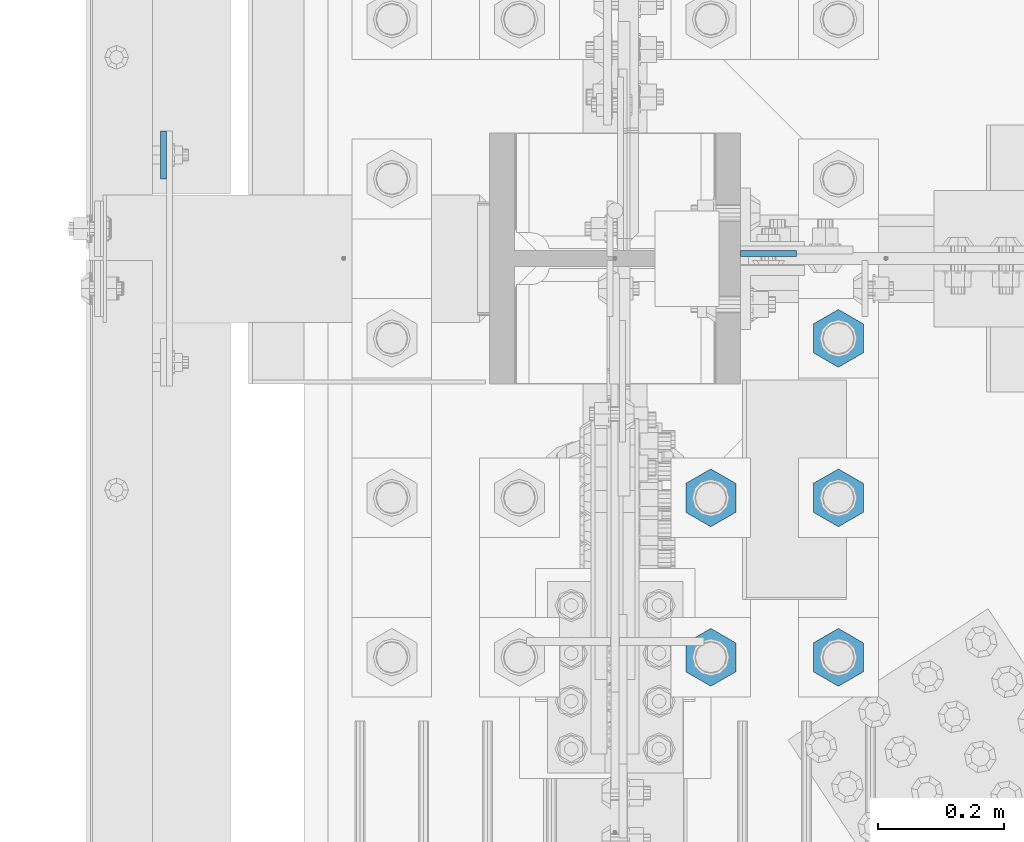
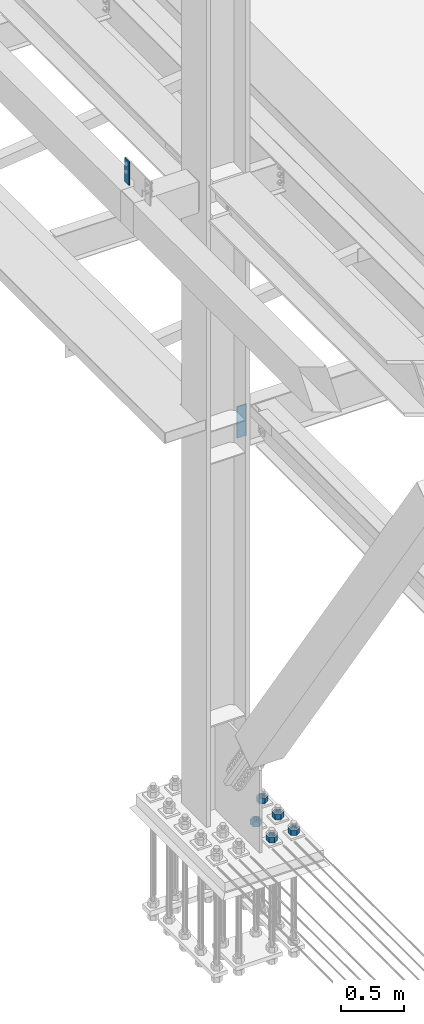
# One storey, part 1554 of 3843: 7 columns, 3 elements without a shape of their own.
"""IFC2X3 building model written with IfcOpenShell, lengths in millimetres."""

from ifc_helpers import new_model, si_unit, frame, origin_with_axes, place, context, subcontext, project, spatial, faceted_brep, material, type_object, element, aggregate, save


model = new_model("IFC2X3")

# Units and contexts
model_context = context("Model", 3, precision=1e-05, world=origin_with_axes())
body_context = subcontext(model_context, "Body", "Model", "MODEL_VIEW")
ifc_project = project(units=[si_unit("LENGTHUNIT", "METRE", prefix="MILLI"), si_unit("AREAUNIT", "SQUARE_METRE"), si_unit("VOLUMEUNIT", "CUBIC_METRE"), si_unit("MASSUNIT", "GRAM", prefix="KILO"), si_unit("TIMEUNIT", "SECOND"), si_unit("PLANEANGLEUNIT", "RADIAN"), si_unit("SOLIDANGLEUNIT", "STERADIAN"), si_unit("THERMODYNAMICTEMPERATUREUNIT", "DEGREE_CELSIUS"), si_unit("LUMINOUSINTENSITYUNIT", "LUMEN")], contexts=[model_context])

# Site, building, storey
site_placement = place(None, origin_with_axes())
site = spatial("IfcSite", under=ifc_project, at=site_placement, CompositionType="ELEMENT")
building_placement = place(site_placement, origin_with_axes())
building = spatial("IfcBuilding", under=site, at=building_placement, Name="Undefined", CompositionType="ELEMENT")
storey_placement = place(building_placement, origin_with_axes())
storey = spatial("IfcBuildingStorey", under=building, at=storey_placement, Name="Undefined", CompositionType="ELEMENT", Elevation=0.0)

# Assembly, column
assembly_1_placement = place(storey_placement, origin_with_axes())
assembly_1 = element("IfcElementAssembly", 1, at=assembly_1_placement, inside=storey, Name="GIRT", AssemblyPlace="NOTDEFINED", PredefinedType="RIGID_FRAME")
ifc_material = material(Name="STEEL/A572-50")
column_type_1 = type_object("IfcColumnType", PredefinedType="NOTDEFINED")
column_1_placement = place(assembly_1_placement, frame((35856.8625, 75793.6, 36404.55), z_axis=(0.0, 1.0, 0.0), x_axis=(0.0, 0.0, 1.0)))
column_1 = element("IfcColumn", 2, at=column_1_placement, type_object=column_type_1, material=ifc_material, Name="PLATE", context=body_context, shape_type="Brep", body=[
    faceted_brep([(0.0, 4.76250000000073, -38.0999999999985), (0.0, 4.76250000000073, 38.0999999999985), (228.599999999999, 4.76249999999709, 38.1000000000058), (228.599999999999, 4.76249999999709, -38.1000000000058), (0.0, -4.76250000000073, 38.0999999999985), (228.599999999999, -4.76249999999709, 38.1000000000058), (0.0, -4.76250000000073, -38.0999999999985), (228.599999999999, -4.76249999999709, -38.1000000000058)], [[[0, 1, 2, 3]], [[1, 4, 5, 2]], [[4, 6, 7, 5]], [[6, 0, 3, 7]], [[5, 7, 3, 2]], [[6, 4, 1, 0]]]),
])
aggregate(assembly_1, [column_1])

assembly_2_placement = place(storey_placement, origin_with_axes())
assembly_2 = element("IfcElementAssembly", 3, at=assembly_2_placement, inside=storey, Name="COLUMN", AssemblyPlace="NOTDEFINED", PredefinedType="RIGID_FRAME")
column_type_2 = type_object("IfcColumnType", PredefinedType="NOTDEFINED")
column_2_placement = place(assembly_2_placement, frame((36820.475, 75636.4375, 33693.0999993376), z_axis=(-1.0, 0.0, 0.0), x_axis=(0.0, 0.0, 1.0)))
column_2 = element("IfcColumn", 4, at=column_2_placement, type_object=column_type_2, material=ifc_material, Name="PLATE", context=body_context, shape_type="Brep", body=[
    faceted_brep([(0.0, 4.76249999999709, -44.4500000000007), (0.0, 4.76249999999709, 44.4500000000007), (304.799999999996, 4.76249999999709, 44.4500000000007), (304.799999999996, 4.76249999999709, -44.4500000000007), (0.0, -4.76249999999709, 44.4500000000007), (304.799999999996, -4.76249999999709, 44.4500000000007), (0.0, -4.76249999999709, -44.4500000000007), (304.799999999996, -4.76249999999709, -44.4500000000007)], [[[0, 1, 2, 3]], [[1, 4, 5, 2]], [[4, 6, 7, 5]], [[6, 0, 3, 7]], [[5, 7, 3, 2]], [[6, 4, 1, 0]]]),
])
aggregate(assembly_2, [column_2])

# Assembly, columns
assembly_3_placement = place(storey_placement, origin_with_axes())
assembly_3 = element("IfcElementAssembly", 5, at=assembly_3_placement, inside=storey, Name="TEMPLATE", AssemblyPlace="NOTDEFINED", PredefinedType="RIGID_FRAME")
column_type_3 = type_object("IfcColumnType", Name="2_HEAVY_HEX_NUT", PredefinedType="NOTDEFINED")
column_3_placement = place(assembly_3_placement, frame((36931.6, 74993.5, 30232.35), z_axis=(1.0, 0.0, 0.0), x_axis=(0.0, 0.0, -1.0)))
column_3 = element("IfcColumn", 6, at=column_3_placement, type_object=column_type_3, material=ifc_material, Name="NUT", ObjectType="2_HEAVY_HEX_NUT", context=body_context, shape_type="Brep", body=[
    faceted_brep([(0.0, -46.0369987487793, 0.0), (0.0, -23.0184993743896, -39.869213104248), (50.7999999999993, -23.0184993743896, -39.869213104248), (50.7999999999993, -46.0369987487793, 0.0), (0.0, 23.0184993743896, -39.869213104248), (50.7999999999993, 23.0184993743896, -39.869213104248), (0.0, 46.0369987487793, 0.0), (50.7999999999993, 46.0369987487793, 0.0), (0.0, 23.0184993743896, 39.869213104248), (50.7999999999993, 23.0184993743896, 39.869213104248), (0.0, -23.0184993743896, 39.869213104248), (50.7999999999993, -23.0184993743896, 39.869213104248), (0.0, 0.0, 26.1940002441406), (0.0, 11.3650617044477, 23.5999013092805), (50.7999999999993, 11.3650617044477, 23.5999013092805), (50.7999999999993, 0.0, 26.1940002441406), (0.0, 20.4791109456419, 16.3316083006721), (50.7999999999993, 20.4791109456419, 16.3316083006721), (0.0, 25.5370200498292, 5.82867859874386), (50.7999999999993, 25.5370200498292, 5.82867859874386), (0.0, 25.5370200498292, -5.82867859874386), (50.7999999999993, 25.5370200498292, -5.82867859874386), (0.0, 20.4791109456419, -16.3316083006721), (50.7999999999993, 20.4791109456419, -16.3316083006721), (0.0, 11.3650617044477, -23.5999013092805), (50.7999999999993, 11.3650617044477, -23.5999013092805), (0.0, 0.0, -26.1940002441406), (50.7999999999993, 0.0, -26.1940002441406), (0.0, -11.3650617044477, -23.5999013092805), (50.7999999999993, -11.3650617044477, -23.5999013092805), (0.0, -20.4791109456419, -16.3316083006721), (50.7999999999993, -20.4791109456419, -16.3316083006721), (0.0, -25.5370200498292, -5.82867859874386), (50.7999999999993, -25.5370200498292, -5.82867859874386), (0.0, -25.5370200498292, 5.82867859874386), (50.7999999999993, -25.5370200498292, 5.82867859874386), (0.0, -20.4791109456419, 16.3316083006721), (50.7999999999993, -20.4791109456419, 16.3316083006721), (0.0, -11.3650617044477, 23.5999013092805), (50.7999999999993, -11.3650617044477, 23.5999013092805)], [[[0, 1, 2, 3]], [[1, 4, 5, 2]], [[4, 6, 7, 5]], [[6, 8, 9, 7]], [[8, 10, 11, 9]], [[10, 0, 3, 11]], [[12, 13, 14, 15]], [[13, 16, 17, 14]], [[16, 18, 19, 17]], [[18, 20, 21, 19]], [[20, 22, 23, 21]], [[22, 24, 25, 23]], [[24, 26, 27, 25]], [[26, 28, 29, 27]], [[28, 30, 31, 29]], [[30, 32, 33, 31]], [[32, 34, 35, 33]], [[34, 36, 37, 35]], [[36, 38, 39, 37]], [[38, 12, 15, 39]], [[5, 7, 9, 11, 3, 2], [17, 19, 21, 23, 25, 27, 29, 31, 33, 35, 37, 39, 15, 14]], [[10, 8, 6, 4, 1, 0], [38, 36, 34, 32, 30, 28, 26, 24, 22, 20, 18, 16, 13, 12]]]),
])
column_4_placement = place(assembly_3_placement, frame((36931.6, 75247.5, 30232.35), z_axis=(1.0, 0.0, 0.0), x_axis=(0.0, 0.0, -1.0)))
column_4 = element("IfcColumn", 7, at=column_4_placement, type_object=column_type_3, material=ifc_material, Name="NUT", ObjectType="2_HEAVY_HEX_NUT", context=body_context, shape_type="Brep", body=[
    faceted_brep([(0.0, -46.0369987487793, 0.0), (0.0, -23.0184993743896, -39.869213104248), (50.7999999999993, -23.0184993743896, -39.869213104248), (50.7999999999993, -46.0369987487793, 0.0), (0.0, 23.0184993743896, -39.869213104248), (50.7999999999993, 23.0184993743896, -39.869213104248), (0.0, 46.0369987487793, 0.0), (50.7999999999993, 46.0369987487793, 0.0), (0.0, 23.0184993743896, 39.869213104248), (50.7999999999993, 23.0184993743896, 39.869213104248), (0.0, -23.0184993743896, 39.869213104248), (50.7999999999993, -23.0184993743896, 39.869213104248), (0.0, 0.0, 26.1940002441406), (0.0, 11.3650617044477, 23.5999013092805), (50.7999999999993, 11.3650617044477, 23.5999013092805), (50.7999999999993, 0.0, 26.1940002441406), (0.0, 20.4791109456419, 16.3316083006721), (50.7999999999993, 20.4791109456419, 16.3316083006721), (0.0, 25.5370200498292, 5.82867859874386), (50.7999999999993, 25.5370200498292, 5.82867859874386), (0.0, 25.5370200498292, -5.82867859874386), (50.7999999999993, 25.5370200498292, -5.82867859874386), (0.0, 20.4791109456419, -16.3316083006721), (50.7999999999993, 20.4791109456419, -16.3316083006721), (0.0, 11.3650617044477, -23.5999013092805), (50.7999999999993, 11.3650617044477, -23.5999013092805), (0.0, 0.0, -26.1940002441406), (50.7999999999993, 0.0, -26.1940002441406), (0.0, -11.3650617044477, -23.5999013092805), (50.7999999999993, -11.3650617044477, -23.5999013092805), (0.0, -20.4791109456419, -16.3316083006721), (50.7999999999993, -20.4791109456419, -16.3316083006721), (0.0, -25.5370200498292, -5.82867859874386), (50.7999999999993, -25.5370200498292, -5.82867859874386), (0.0, -25.5370200498292, 5.82867859874386), (50.7999999999993, -25.5370200498292, 5.82867859874386), (0.0, -20.4791109456419, 16.3316083006721), (50.7999999999993, -20.4791109456419, 16.3316083006721), (0.0, -11.3650617044477, 23.5999013092805), (50.7999999999993, -11.3650617044477, 23.5999013092805)], [[[0, 1, 2, 3]], [[1, 4, 5, 2]], [[4, 6, 7, 5]], [[6, 8, 9, 7]], [[8, 10, 11, 9]], [[10, 0, 3, 11]], [[12, 13, 14, 15]], [[13, 16, 17, 14]], [[16, 18, 19, 17]], [[18, 20, 21, 19]], [[20, 22, 23, 21]], [[22, 24, 25, 23]], [[24, 26, 27, 25]], [[26, 28, 29, 27]], [[28, 30, 31, 29]], [[30, 32, 33, 31]], [[32, 34, 35, 33]], [[34, 36, 37, 35]], [[36, 38, 39, 37]], [[38, 12, 15, 39]], [[5, 7, 9, 11, 3, 2], [17, 19, 21, 23, 25, 27, 29, 31, 33, 35, 37, 39, 15, 14]], [[10, 8, 6, 4, 1, 0], [38, 36, 34, 32, 30, 28, 26, 24, 22, 20, 18, 16, 13, 12]]]),
])
column_5_placement = place(assembly_3_placement, frame((36931.6, 75501.5, 30232.35), z_axis=(1.0, 0.0, 0.0), x_axis=(0.0, 0.0, -1.0)))
column_5 = element("IfcColumn", 8, at=column_5_placement, type_object=column_type_3, material=ifc_material, Name="NUT", ObjectType="2_HEAVY_HEX_NUT", context=body_context, shape_type="Brep", body=[
    faceted_brep([(0.0, -46.0369987487793, 0.0), (0.0, -23.0184993743896, -39.869213104248), (50.7999999999993, -23.0184993743896, -39.869213104248), (50.7999999999993, -46.0369987487793, 0.0), (0.0, 23.0184993743896, -39.869213104248), (50.7999999999993, 23.0184993743896, -39.869213104248), (0.0, 46.0369987487793, 0.0), (50.7999999999993, 46.0369987487793, 0.0), (0.0, 23.0184993743896, 39.869213104248), (50.7999999999993, 23.0184993743896, 39.869213104248), (0.0, -23.0184993743896, 39.869213104248), (50.7999999999993, -23.0184993743896, 39.869213104248), (0.0, 0.0, 26.1940002441406), (0.0, 11.3650617044477, 23.5999013092805), (50.7999999999993, 11.3650617044477, 23.5999013092805), (50.7999999999993, 0.0, 26.1940002441406), (0.0, 20.4791109456419, 16.3316083006721), (50.7999999999993, 20.4791109456419, 16.3316083006721), (0.0, 25.5370200498292, 5.82867859874386), (50.7999999999993, 25.5370200498292, 5.82867859874386), (0.0, 25.5370200498292, -5.82867859874386), (50.7999999999993, 25.5370200498292, -5.82867859874386), (0.0, 20.4791109456419, -16.3316083006721), (50.7999999999993, 20.4791109456419, -16.3316083006721), (0.0, 11.3650617044477, -23.5999013092805), (50.7999999999993, 11.3650617044477, -23.5999013092805), (0.0, 0.0, -26.1940002441406), (50.7999999999993, 0.0, -26.1940002441406), (0.0, -11.3650617044477, -23.5999013092805), (50.7999999999993, -11.3650617044477, -23.5999013092805), (0.0, -20.4791109456419, -16.3316083006721), (50.7999999999993, -20.4791109456419, -16.3316083006721), (0.0, -25.5370200498292, -5.82867859874386), (50.7999999999993, -25.5370200498292, -5.82867859874386), (0.0, -25.5370200498292, 5.82867859874386), (50.7999999999993, -25.5370200498292, 5.82867859874386), (0.0, -20.4791109456419, 16.3316083006721), (50.7999999999993, -20.4791109456419, 16.3316083006721), (0.0, -11.3650617044477, 23.5999013092805), (50.7999999999993, -11.3650617044477, 23.5999013092805)], [[[0, 1, 2, 3]], [[1, 4, 5, 2]], [[4, 6, 7, 5]], [[6, 8, 9, 7]], [[8, 10, 11, 9]], [[10, 0, 3, 11]], [[12, 13, 14, 15]], [[13, 16, 17, 14]], [[16, 18, 19, 17]], [[18, 20, 21, 19]], [[20, 22, 23, 21]], [[22, 24, 25, 23]], [[24, 26, 27, 25]], [[26, 28, 29, 27]], [[28, 30, 31, 29]], [[30, 32, 33, 31]], [[32, 34, 35, 33]], [[34, 36, 37, 35]], [[36, 38, 39, 37]], [[38, 12, 15, 39]], [[5, 7, 9, 11, 3, 2], [17, 19, 21, 23, 25, 27, 29, 31, 33, 35, 37, 39, 15, 14]], [[10, 8, 6, 4, 1, 0], [38, 36, 34, 32, 30, 28, 26, 24, 22, 20, 18, 16, 13, 12]]]),
])
column_6_placement = place(assembly_3_placement, frame((36728.4, 74993.5, 30232.35), z_axis=(1.0, 0.0, 0.0), x_axis=(0.0, 0.0, -1.0)))
column_6 = element("IfcColumn", 9, at=column_6_placement, type_object=column_type_3, material=ifc_material, Name="NUT", ObjectType="2_HEAVY_HEX_NUT", context=body_context, shape_type="Brep", body=[
    faceted_brep([(0.0, -46.0369987487793, 0.0), (0.0, -23.0184993743896, -39.869213104248), (50.7999999999993, -23.0184993743896, -39.869213104248), (50.7999999999993, -46.0369987487793, 0.0), (0.0, 23.0184993743896, -39.869213104248), (50.7999999999993, 23.0184993743896, -39.869213104248), (0.0, 46.0369987487793, 0.0), (50.7999999999993, 46.0369987487793, 0.0), (0.0, 23.0184993743896, 39.869213104248), (50.7999999999993, 23.0184993743896, 39.869213104248), (0.0, -23.0184993743896, 39.869213104248), (50.7999999999993, -23.0184993743896, 39.869213104248), (0.0, 0.0, 26.1940002441406), (0.0, 11.3650617044477, 23.5999013092805), (50.7999999999993, 11.3650617044477, 23.5999013092805), (50.7999999999993, 0.0, 26.1940002441406), (0.0, 20.4791109456419, 16.3316083006721), (50.7999999999993, 20.4791109456419, 16.3316083006721), (0.0, 25.5370200498292, 5.82867859874386), (50.7999999999993, 25.5370200498292, 5.82867859874386), (0.0, 25.5370200498292, -5.82867859874386), (50.7999999999993, 25.5370200498292, -5.82867859874386), (0.0, 20.4791109456419, -16.3316083006721), (50.7999999999993, 20.4791109456419, -16.3316083006721), (0.0, 11.3650617044477, -23.5999013092805), (50.7999999999993, 11.3650617044477, -23.5999013092805), (0.0, 0.0, -26.1940002441406), (50.7999999999993, 0.0, -26.1940002441406), (0.0, -11.3650617044477, -23.5999013092805), (50.7999999999993, -11.3650617044477, -23.5999013092805), (0.0, -20.4791109456419, -16.3316083006721), (50.7999999999993, -20.4791109456419, -16.3316083006721), (0.0, -25.5370200498292, -5.82867859874386), (50.7999999999993, -25.5370200498292, -5.82867859874386), (0.0, -25.5370200498292, 5.82867859874386), (50.7999999999993, -25.5370200498292, 5.82867859874386), (0.0, -20.4791109456419, 16.3316083006721), (50.7999999999993, -20.4791109456419, 16.3316083006721), (0.0, -11.3650617044477, 23.5999013092805), (50.7999999999993, -11.3650617044477, 23.5999013092805)], [[[0, 1, 2, 3]], [[1, 4, 5, 2]], [[4, 6, 7, 5]], [[6, 8, 9, 7]], [[8, 10, 11, 9]], [[10, 0, 3, 11]], [[12, 13, 14, 15]], [[13, 16, 17, 14]], [[16, 18, 19, 17]], [[18, 20, 21, 19]], [[20, 22, 23, 21]], [[22, 24, 25, 23]], [[24, 26, 27, 25]], [[26, 28, 29, 27]], [[28, 30, 31, 29]], [[30, 32, 33, 31]], [[32, 34, 35, 33]], [[34, 36, 37, 35]], [[36, 38, 39, 37]], [[38, 12, 15, 39]], [[5, 7, 9, 11, 3, 2], [17, 19, 21, 23, 25, 27, 29, 31, 33, 35, 37, 39, 15, 14]], [[10, 8, 6, 4, 1, 0], [38, 36, 34, 32, 30, 28, 26, 24, 22, 20, 18, 16, 13, 12]]]),
])
column_7_placement = place(assembly_3_placement, frame((36728.4, 75247.5, 30232.35), z_axis=(1.0, 0.0, 0.0), x_axis=(0.0, 0.0, -1.0)))
column_7 = element("IfcColumn", 10, at=column_7_placement, type_object=column_type_3, material=ifc_material, Name="NUT", ObjectType="2_HEAVY_HEX_NUT", context=body_context, shape_type="Brep", body=[
    faceted_brep([(0.0, -46.0369987487793, 0.0), (0.0, -23.0184993743896, -39.869213104248), (50.7999999999993, -23.0184993743896, -39.869213104248), (50.7999999999993, -46.0369987487793, 0.0), (0.0, 23.0184993743896, -39.869213104248), (50.7999999999993, 23.0184993743896, -39.869213104248), (0.0, 46.0369987487793, 0.0), (50.7999999999993, 46.0369987487793, 0.0), (0.0, 23.0184993743896, 39.869213104248), (50.7999999999993, 23.0184993743896, 39.869213104248), (0.0, -23.0184993743896, 39.869213104248), (50.7999999999993, -23.0184993743896, 39.869213104248), (0.0, 0.0, 26.1940002441406), (0.0, 11.3650617044477, 23.5999013092805), (50.7999999999993, 11.3650617044477, 23.5999013092805), (50.7999999999993, 0.0, 26.1940002441406), (0.0, 20.4791109456419, 16.3316083006721), (50.7999999999993, 20.4791109456419, 16.3316083006721), (0.0, 25.5370200498292, 5.82867859874386), (50.7999999999993, 25.5370200498292, 5.82867859874386), (0.0, 25.5370200498292, -5.82867859874386), (50.7999999999993, 25.5370200498292, -5.82867859874386), (0.0, 20.4791109456419, -16.3316083006721), (50.7999999999993, 20.4791109456419, -16.3316083006721), (0.0, 11.3650617044477, -23.5999013092805), (50.7999999999993, 11.3650617044477, -23.5999013092805), (0.0, 0.0, -26.1940002441406), (50.7999999999993, 0.0, -26.1940002441406), (0.0, -11.3650617044477, -23.5999013092805), (50.7999999999993, -11.3650617044477, -23.5999013092805), (0.0, -20.4791109456419, -16.3316083006721), (50.7999999999993, -20.4791109456419, -16.3316083006721), (0.0, -25.5370200498292, -5.82867859874386), (50.7999999999993, -25.5370200498292, -5.82867859874386), (0.0, -25.5370200498292, 5.82867859874386), (50.7999999999993, -25.5370200498292, 5.82867859874386), (0.0, -20.4791109456419, 16.3316083006721), (50.7999999999993, -20.4791109456419, 16.3316083006721), (0.0, -11.3650617044477, 23.5999013092805), (50.7999999999993, -11.3650617044477, 23.5999013092805)], [[[0, 1, 2, 3]], [[1, 4, 5, 2]], [[4, 6, 7, 5]], [[6, 8, 9, 7]], [[8, 10, 11, 9]], [[10, 0, 3, 11]], [[12, 13, 14, 15]], [[13, 16, 17, 14]], [[16, 18, 19, 17]], [[18, 20, 21, 19]], [[20, 22, 23, 21]], [[22, 24, 25, 23]], [[24, 26, 27, 25]], [[26, 28, 29, 27]], [[28, 30, 31, 29]], [[30, 32, 33, 31]], [[32, 34, 35, 33]], [[34, 36, 37, 35]], [[36, 38, 39, 37]], [[38, 12, 15, 39]], [[5, 7, 9, 11, 3, 2], [17, 19, 21, 23, 25, 27, 29, 31, 33, 35, 37, 39, 15, 14]], [[10, 8, 6, 4, 1, 0], [38, 36, 34, 32, 30, 28, 26, 24, 22, 20, 18, 16, 13, 12]]]),
])
aggregate(assembly_3, [column_3, column_4, column_5, column_6, column_7])

save(model, "model.ifc")
